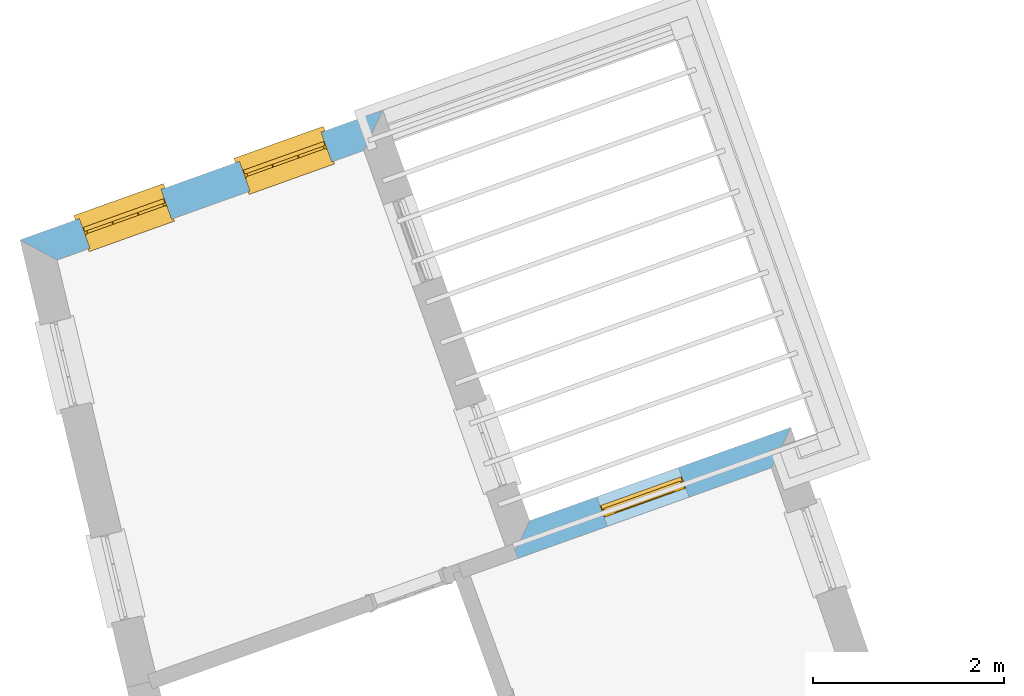
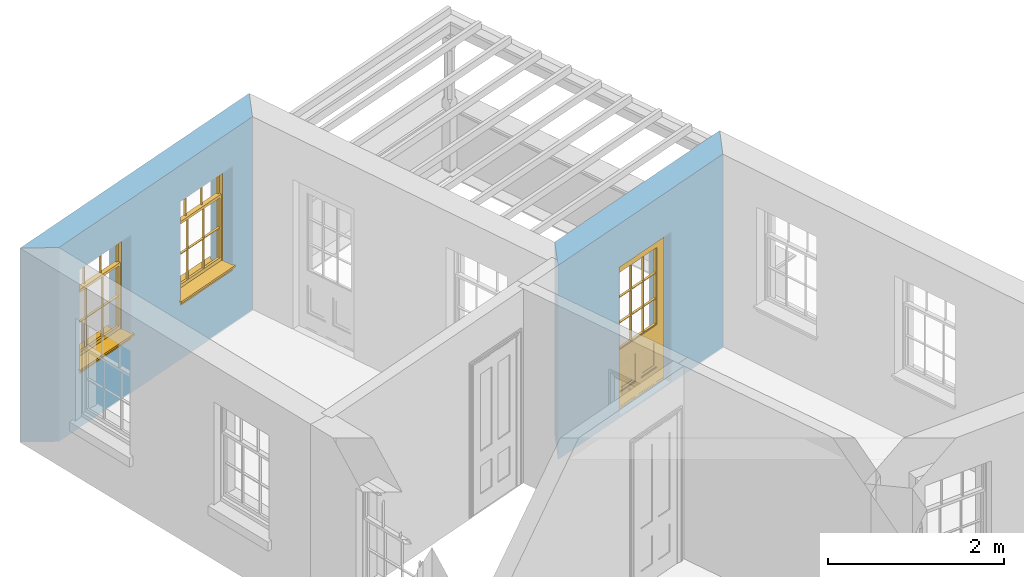
# One storey, part 10 of 12: 2 windows, 1 door, 3 openings, plus 2 elements that do not belong to this part.
"""IFC2X3 building model written with IfcOpenShell, lengths in metres."""

from ifc_helpers import new_model, si_unit, frame, origin, place, context, subcontext, project, spatial, polyline, outline, extrude, faceted_brep, material, layer, layer_set, layer_usage, element, fill, save


model = new_model("IFC2X3")

# Units and contexts
model_context = context("Model", 3, world=origin())
body_context = subcontext(model_context, "Body", "Model", "MODEL_VIEW")
ifc_project = project(units=[si_unit("PLANEANGLEUNIT", "RADIAN"), si_unit("MASSUNIT", "GRAM", prefix="KILO"), si_unit("FORCEUNIT", "NEWTON", prefix="KILO"), si_unit("LENGTHUNIT", "METRE")], contexts=[model_context])

# Site, building, storey
site_placement = place(None, origin())
site = spatial("IfcSite", under=ifc_project, at=site_placement, CompositionType="ELEMENT")
building_placement = place(None, origin())
building = spatial("IfcBuilding", under=site, at=building_placement, Name="Building plot-12", CompositionType="ELEMENT")
storey_placement = place(None, frame((0.0, 0.0, 6.45)))
storey = spatial("IfcBuildingStorey", under=building, at=storey_placement, Name="Floor 1", CompositionType="ELEMENT", Elevation=6.45)

# Wall, opening, door
ifc_material = material(Name="Masonry")
ifc_layer = layer(ifc_material, 0.33, ventilated=False)
ifc_layer_set = layer_set([ifc_layer], Name="My Wall")
ifc_layer_usage = layer_usage(ifc_layer_set, "AXIS2", "NEGATIVE", 0.08)
wall_1_placement = place(storey_placement, origin())
wall_1 = element("IfcWallStandardCase", 1, at=wall_1_placement, inside=storey, material=ifc_layer_usage, Name="exterior", context=body_context, shape_type="SweptSolid", body=[
    extrude(outline(polyline([(60.6224114250311, 40.801918386454), (60.8252944529976, 41.2249256313146), (58.0905645178046, 40.247064339734), (57.8909410000931, 39.8252226026139), (60.6224114250311, 40.801918386454)])), origin(), (0.0, 0.0, 1.0), 2.7),
])
opening_1_placement = place(storey_placement, frame((0.0, 0.0, 0.0199999999999996)))
opening_1 = element("IfcOpeningElement", 2, at=opening_1_placement, cuts=wall_1, Name="Opening", ObjectType="Opening", context=body_context, shape_type="SweptSolid", body=[
    extrude(outline(polyline([(59.6497256970325, 40.804575831045), (58.7928569365829, 40.4981840436785), (58.9039660462872, 40.1874514162628), (59.7608348067368, 40.4938432036292), (59.6497256970325, 40.804575831045)])), origin(), (0.0, 0.0, 1.0), 2.08),
])
door_placement = place(storey_placement, frame((59.7338992649903, 40.569172325427, 0.0199999999999996), z_axis=(0.0, 0.0, 1.0), x_axis=(-0.856868760449572, -0.306391787366451, 0.0)))
door = element("IfcDoor", 3, at=door_placement, inside=storey, Name="bedroom outside door", OverallHeight=2.08, OverallWidth=0.91, context=body_context, shape_type="Brep", held_by="IfcProductRepresentation", body=[
    faceted_brep([(0.545, -0.055, 0.265), (0.745, -0.055, 0.265), (0.745, -0.05, 0.265), (0.545, -0.05, 0.265), (0.745, -0.05, 0.58), (0.545, -0.05, 0.58), (0.545, -0.055, 0.58), (0.515, -0.06, 0.235), (0.775, -0.06, 0.235), (0.745, -0.055, 0.58), (0.515, -0.06, 0.61), (0.515, -0.065, 0.235), (0.775, -0.065, 0.235), (0.775, -0.06, 0.61), (0.515, -0.065, 0.61), (0.785, -0.065, 0.225), (0.505, -0.065, 0.225), (0.775, -0.065, 0.61), (0.505, -0.065, 0.62), (0.785, -0.065, 0.62), (0.505, -0.07, 0.225), (0.785, -0.07, 0.225), (0.505, -0.07, 0.62), (0.785, -0.07, 0.62), (0.883, -0.07, 0.075), (0.898, -0.07, 0.075), (0.405, -0.07, 0.62), (0.405, -0.07, 0.225), (0.027, -0.07, 0.075), (0.785, -0.07, 0.82), (0.125, -0.07, 0.82), (0.405, -0.065, 0.62), (0.405, -0.065, 0.225), (0.898, -0.07, 2.068), (0.027, -0.08, 0.075), (0.883, -0.08, 0.075), (0.125, -0.07, 0.225), (0.012, -0.07, 0.075), (0.785, -0.06, 0.82), (0.125, -0.06, 0.82), (0.125, -0.07, 0.62), (0.125, -0.065, 0.62), (0.395, -0.065, 0.61), (0.395, -0.065, 0.235), (0.125, -0.065, 0.225), (0.785, -0.07, 1.895), (0.027, -0.11, 0.045), (0.883, -0.11, 0.045), (0.558333, -0.06, 0.83), (0.351667, -0.06, 0.83), (0.125, -0.07, 1.895), (0.125, -0.06, 1.895), (0.785, -0.06, 1.895), (0.012, -0.07, 2.068), (0.135, -0.065, 0.61), (0.395, -0.06, 0.61), (0.395, -0.06, 0.235), (0.135, -0.065, 0.235), (0.027, -0.11, 0.027), (0.883, -0.11, 0.027), (0.568333, -0.06, 0.83), (0.558333, -0.03, 0.83), (0.351667, -0.03, 0.83), (0.341667, -0.06, 0.83), (0.135, -0.06, 1.185), (0.135, -0.06, 1.53), (0.775, -0.06, 1.53), (0.775, -0.06, 1.185), (0.135, -0.06, 0.61), (0.365, -0.055, 0.58), (0.365, -0.055, 0.265), (0.135, -0.06, 0.235), (0.568333, -0.06, 1.175), (0.558333, -0.06, 1.175), (0.775, -0.06, 0.83), (0.558333, -0.03, 1.175), (0.785, -0.03, 0.82), (0.125, -0.03, 0.82), (0.351667, -0.03, 1.175), (0.351667, -0.06, 1.175), (0.341667, -0.06, 1.175), (0.135, -0.06, 0.83), (0.135, -0.06, 1.175), (0.135, -0.03, 1.185), (0.135, -0.03, 1.53), (0.135, -0.06, 1.54), (0.351667, -0.06, 1.885), (0.558333, -0.06, 1.885), (0.775, -0.03, 1.53), (0.775, -0.03, 1.185), (0.775, -0.06, 1.175), (0.775, -0.06, 1.54), (0.165, -0.055, 0.58), (0.365, -0.05, 0.58), (0.365, -0.05, 0.265), (0.165, -0.055, 0.265), (0.568333, -0.03, 0.83), (0.568333, -0.03, 1.175), (0.568333, -0.06, 1.185), (0.558333, -0.06, 1.185), (0.775, -0.03, 0.83), (0.785, -0.02, 0.82), (0.125, -0.02, 0.82), (0.341667, -0.03, 0.83), (0.341667, -0.03, 1.175), (0.351667, -0.06, 1.185), (0.341667, -0.06, 1.185), (0.135, -0.03, 0.83), (0.341667, -0.03, 1.185), (0.125, -0.03, 1.895), (0.341667, -0.03, 1.53), (0.341667, -0.06, 1.53), (0.135, -0.06, 1.885), (0.341667, -0.06, 1.54), (0.341667, -0.06, 1.885), (0.558333, -0.03, 1.885), (0.351667, -0.03, 1.885), (0.568333, -0.06, 1.885), (0.785, -0.03, 1.895), (0.568333, -0.03, 1.185), (0.568333, -0.06, 1.53), (0.568333, -0.03, 1.53), (0.568333, -0.06, 1.54), (0.775, -0.06, 1.885), (0.165, -0.05, 0.58), (0.165, -0.05, 0.265), (0.775, -0.03, 1.175), (0.558333, -0.06, 1.53), (0.351667, -0.03, 1.185), (0.558333, -0.03, 1.185), (0.505, -0.02, 0.62), (0.405, -0.02, 0.62), (0.125, -0.02, 1.895), (0.785, -0.02, 1.895), (0.351667, -0.06, 1.53), (0.135, -0.03, 1.175), (0.135, -0.03, 1.54), (0.341667, -0.03, 1.54), (0.135, -0.03, 1.885), (0.351667, -0.06, 1.54), (0.558333, -0.03, 1.54), (0.558333, -0.06, 1.54), (0.351667, -0.03, 1.54), (0.775, -0.03, 1.54), (0.568333, -0.03, 1.54), (0.775, -0.03, 1.885), (0.558333, -0.03, 1.53), (0.405, -0.02, 0.225), (0.505, -0.02, 0.225), (0.125, -0.02, 0.62), (0.785, -0.02, 0.62), (0.012, -0.02, 2.068), (0.898, -0.02, 2.068), (0.351667, -0.03, 1.53), (0.341667, -0.03, 1.885), (0.568333, -0.03, 1.885), (0.405, -0.025, 0.225), (0.405, -0.025, 0.62), (0.505, -0.025, 0.62), (0.505, -0.025, 0.225), (0.898, -0.02, 0.027), (0.012, -0.02, 0.027), (0.125, -0.025, 0.62), (0.785, -0.025, 0.62), (0.395, -0.025, 0.235), (0.395, -0.025, 0.61), (0.125, -0.02, 0.225), (0.125, -0.025, 0.225), (0.515, -0.025, 0.61), (0.515, -0.025, 0.235), (0.785, -0.02, 0.225), (0.785, -0.025, 0.225), (0.135, -0.025, 0.61), (0.775, -0.025, 0.61), (0.135, -0.025, 0.235), (0.395, -0.03, 0.235), (0.395, -0.03, 0.61), (0.515, -0.03, 0.61), (0.515, -0.03, 0.235), (0.775, -0.025, 0.235), (0.135, -0.03, 0.61), (0.775, -0.03, 0.61), (0.135, -0.03, 0.235), (0.365, -0.035, 0.265), (0.365, -0.035, 0.58), (0.545, -0.035, 0.58), (0.545, -0.035, 0.265), (0.775, -0.03, 0.235), (0.165, -0.035, 0.58), (0.745, -0.035, 0.58), (0.165, -0.035, 0.265), (0.365, -0.04, 0.58), (0.365, -0.04, 0.265), (0.545, -0.04, 0.58), (0.545, -0.04, 0.265), (0.745, -0.035, 0.265), (0.165, -0.04, 0.58), (0.745, -0.04, 0.58), (0.165, -0.04, 0.265), (0.745, -0.04, 0.265), (0.885, -0.072, 0.025), (0.025, -0.072, 0.025), (0.025, -0.1, 0.025), (0.885, -0.1, 0.025), (0.9, -0.02, 0.025), (0.01, -0.02, 0.025), (0.9, -0.072, 0.025), (0.91, -0.02, 0.0), (0.0, -0.02, 0.0), (0.01, -0.072, 0.025), (0.9, -0.072, 2.07), (0.9, -0.02, 2.07), (0.885, -0.072, 2.055), (0.91, -0.02, 2.08), (0.01, -0.02, 2.07), (0.0, -0.02, 2.08), (0.01, -0.072, 2.07), (0.025, -0.072, 2.055), (0.0, -0.15, 2.08), (0.91, -0.15, 2.08), (0.01, -0.15, 2.07), (0.9, -0.15, 2.07), (0.01, -0.1, 2.07), (0.9, -0.1, 2.07), (0.0, -0.15, 0.0), (0.91, -0.15, 0.0), (0.01, -0.15, 0.025), (0.9, -0.15, 0.025), (0.01, -0.1, 0.025), (0.025, -0.1, 2.055), (0.9, -0.1, 0.025), (0.885, -0.1, 2.055), (0.898, -0.07, 0.027), (0.012, -0.07, 0.027), (0.883, -0.07, 0.027), (0.027, -0.07, 0.027)], [[[0, 1, 2, 3]], [[2, 4, 5, 3]], [[0, 3, 5, 6]], [[1, 0, 7, 8]], [[9, 4, 2, 1]], [[9, 6, 5, 4]], [[0, 6, 10, 7]], [[8, 7, 11, 12]], [[8, 13, 9, 1]], [[13, 10, 6, 9]], [[7, 10, 14, 11]], [[15, 12, 11, 16]], [[12, 17, 13, 8]], [[17, 14, 10, 13]], [[18, 16, 11, 14]], [[15, 19, 17, 12]], [[15, 16, 20, 21]], [[14, 17, 19, 18]], [[16, 18, 22, 20]], [[21, 23, 19, 15]], [[24, 25, 21, 20]], [[23, 22, 18, 19]], [[20, 22, 26, 27]], [[23, 21, 25]], [[28, 24, 20, 27]], [[22, 23, 29]], [[29, 30, 26, 22]], [[27, 26, 31, 32]], [[23, 25, 33, 29]], [[34, 35, 24, 28]], [[28, 27, 36, 37]], [[38, 39, 30, 29]], [[26, 30, 40]], [[26, 40, 41, 31]], [[42, 43, 32, 31]], [[32, 44, 36, 27]], [[33, 45, 29]], [[46, 47, 35, 34]], [[36, 40, 37]], [[39, 38, 48, 49]], [[50, 30, 39, 51]], [[29, 45, 52, 38]], [[53, 37, 40, 30]], [[44, 41, 40, 36]], [[31, 41, 54, 42]], [[43, 42, 55, 56]], [[57, 44, 32, 43]], [[50, 45, 33, 53]], [[47, 46, 58, 59]], [[60, 48, 38]], [[49, 48, 61, 62]], [[49, 63, 39]], [[50, 53, 30]], [[51, 39, 64, 65]], [[45, 50, 51, 52]], [[66, 67, 38, 52]], [[57, 54, 41, 44]], [[42, 54, 68, 55]], [[56, 55, 69, 70]], [[56, 71, 57, 43]], [[60, 72, 73, 48]], [[60, 38, 74]], [[48, 73, 75, 61]], [[76, 77, 62, 61]], [[62, 78, 79, 49]], [[49, 79, 80, 63]], [[63, 81, 39]], [[82, 64, 39]], [[65, 64, 83, 84]], [[85, 51, 65]], [[52, 51, 86, 87]], [[88, 89, 67, 66]], [[90, 38, 67]], [[91, 66, 52]], [[71, 68, 54, 57]], [[55, 68, 92, 69]], [[69, 93, 94, 70]], [[70, 95, 71, 56]], [[96, 97, 72, 60]], [[73, 72, 98, 99]], [[74, 38, 90]], [[100, 96, 60, 74]], [[75, 73, 79, 78]], [[61, 75, 97, 96]], [[101, 102, 77, 76]], [[77, 103, 62]], [[96, 76, 61]], [[103, 104, 78, 62]], [[80, 79, 105, 106]], [[63, 80, 104, 103]], [[81, 63, 103, 107]], [[81, 82, 39]], [[106, 64, 82, 80]], [[106, 108, 83, 64]], [[84, 83, 77, 109]], [[110, 111, 65, 84]], [[112, 51, 85]], [[113, 85, 65, 111]], [[114, 86, 51]], [[115, 87, 86, 116]], [[117, 52, 87]], [[118, 76, 89, 88]], [[119, 98, 67, 89]], [[120, 121, 88, 66]], [[67, 98, 72, 90]], [[91, 122, 120, 66]], [[91, 52, 123]], [[95, 92, 68, 71]], [[69, 92, 124, 93]], [[94, 93, 124, 125]], [[94, 125, 95, 70]], [[72, 97, 126, 90]], [[127, 99, 98, 120]], [[99, 105, 79, 73]], [[74, 90, 126, 100]], [[96, 100, 76]], [[128, 129, 75, 78]], [[97, 75, 129, 119]], [[130, 131, 102, 101]], [[109, 77, 102, 132]], [[133, 101, 76, 118]], [[77, 107, 103]], [[78, 104, 108, 128]], [[111, 106, 105, 134]], [[104, 80, 82, 135]], [[107, 135, 82, 81]], [[110, 108, 106, 111]], [[104, 135, 83, 108]], [[83, 135, 77]], [[136, 84, 109]], [[110, 84, 136, 137]], [[114, 51, 112]], [[85, 136, 138, 112]], [[113, 137, 136, 85]], [[111, 134, 139, 113]], [[86, 114, 113, 139]], [[140, 141, 87, 115]], [[139, 142, 116, 86]], [[109, 118, 115, 116]], [[117, 123, 52]], [[117, 87, 141, 122]], [[126, 89, 76]], [[143, 118, 88]], [[120, 98, 119, 121]], [[119, 89, 126, 97]], [[144, 143, 88, 121]], [[144, 122, 91, 143]], [[127, 120, 122, 141]], [[143, 91, 123, 145]], [[124, 92, 95, 125]], [[146, 129, 99, 127]], [[99, 129, 128, 105]], [[100, 126, 76]], [[121, 119, 129, 146]], [[147, 131, 130, 148]], [[131, 149, 102]], [[130, 101, 150]], [[102, 151, 132]], [[118, 109, 132, 133]], [[101, 133, 152]], [[107, 77, 135]], [[153, 128, 108, 110]], [[134, 105, 128, 153]], [[109, 138, 136]], [[153, 110, 137, 142]], [[154, 114, 112, 138]], [[137, 113, 114, 154]], [[141, 139, 134, 127]], [[141, 140, 142, 139]], [[144, 140, 115, 155]], [[142, 137, 154, 116]], [[155, 115, 118]], [[116, 154, 109]], [[117, 155, 145, 123]], [[122, 144, 155, 117]], [[143, 145, 118]], [[121, 146, 140, 144]], [[146, 127, 134, 153]], [[156, 157, 131, 147]], [[148, 130, 158, 159]], [[148, 160, 161, 147]], [[157, 162, 149, 131]], [[161, 151, 102, 149]], [[101, 152, 160, 150]], [[163, 158, 130, 150]], [[151, 152, 133, 132]], [[154, 138, 109]], [[142, 140, 146, 153]], [[145, 155, 118]], [[157, 156, 164, 165]], [[147, 166, 167, 156]], [[168, 169, 159, 158]], [[170, 148, 159, 171]], [[148, 170, 160]], [[166, 147, 161]], [[172, 162, 157, 165]], [[166, 149, 162, 167]], [[166, 161, 149]], [[150, 160, 170]], [[163, 173, 168, 158]], [[171, 163, 150, 170]], [[174, 164, 156, 167]], [[175, 176, 165, 164]], [[169, 168, 177, 178]], [[171, 159, 169, 179]], [[167, 162, 172, 174]], [[176, 180, 172, 165]], [[179, 173, 163, 171]], [[181, 177, 168, 173]], [[164, 174, 182, 175]], [[183, 184, 176, 175]], [[178, 177, 185, 186]], [[179, 169, 178, 187]], [[174, 172, 180, 182]], [[184, 188, 180, 176]], [[187, 181, 173, 179]], [[189, 185, 177, 181]], [[175, 182, 190, 183]], [[191, 184, 183, 192]], [[185, 193, 194, 186]], [[187, 178, 186, 195]], [[182, 180, 188, 190]], [[191, 196, 188, 184]], [[195, 189, 181, 187]], [[197, 193, 185, 189]], [[183, 190, 198, 192]], [[198, 196, 191, 192]], [[194, 193, 197, 199]], [[195, 186, 194, 199]], [[188, 196, 198, 190]], [[197, 189, 195, 199]], [[200, 201, 202, 203]], [[201, 200, 204, 205]], [[206, 204, 200]], [[204, 207, 208, 205]], [[209, 201, 205]], [[210, 211, 204, 206]], [[206, 200, 212, 210]], [[211, 213, 207, 204]], [[214, 205, 208, 215]], [[216, 217, 201, 209]], [[205, 214, 216, 209]], [[216, 214, 211, 210]], [[210, 212, 217, 216]], [[214, 215, 213, 211]], [[218, 219, 213, 215]], [[219, 218, 220, 221]], [[221, 220, 222, 223]], [[215, 208, 224, 218]], [[225, 224, 208, 207]], [[224, 226, 220, 218]], [[224, 225, 227, 226]], [[219, 225, 207, 213]], [[228, 222, 220, 226]], [[219, 221, 227, 225]], [[226, 227, 203, 202]], [[202, 229, 222, 228]], [[228, 226, 202]], [[227, 221, 223, 230]], [[230, 203, 227]], [[217, 229, 202, 201]], [[231, 223, 222, 229]], [[230, 223, 231, 203]], [[231, 229, 217, 212]], [[212, 200, 203, 231]], [[33, 152, 151, 53]], [[25, 160, 152, 33]], [[161, 37, 53, 151]], [[232, 160, 25]], [[161, 233, 37]], [[160, 232, 234]], [[24, 234, 232, 25]], [[233, 161, 235]], [[37, 233, 235, 28]], [[161, 160, 234, 235]], [[35, 47, 234, 24]], [[28, 235, 46, 34]], [[58, 235, 234, 59]], [[59, 234, 47]], [[58, 46, 235]]]),
])
fill(opening_1, door)

# Wall, openings, windows
wall_2_placement = place(storey_placement, origin())
wall_2 = element("IfcWallStandardCase", 4, at=wall_2_placement, inside=storey, material=ifc_layer_usage, Name="exterior", context=body_context, shape_type="SweptSolid", body=[
    extrude(outline(polyline([(56.3536968527592, 44.1243472572147), (56.5533203704707, 44.5461889943348), (52.7542538663581, 43.1877513545865), (53.1438565991735, 42.9766000900277), (56.3536968527592, 44.1243472572147)])), origin(), (0.0, 0.0, 1.0), 2.7),
])
opening_2_placement = place(storey_placement, frame((0.0, 0.0, 0.75)))
opening_2 = element("IfcOpeningElement", 5, at=opening_2_placement, cuts=wall_2, Name="Opening", ObjectType="Opening", context=body_context, shape_type="SweptSolid", body=[
    extrude(outline(polyline([(55.9081804998309, 44.3155054087142), (55.0513117393813, 44.0091136213478), (55.1624208490857, 43.698380993932), (56.0192896095352, 44.0047727812985), (55.9081804998309, 44.3155054087142)])), origin(), (0.0, 0.0, 1.0), 1.445),
])
opening_3_placement = place(storey_placement, frame((0.0, 0.0, 0.75)))
opening_3 = element("IfcOpeningElement", 6, at=opening_3_placement, cuts=wall_2, Name="Opening", ObjectType="Opening", context=body_context, shape_type="SweptSolid", body=[
    extrude(outline(polyline([(54.2318390093378, 43.7160935860224), (53.3749702488882, 43.409701798656), (53.4860793585926, 43.0989691712402), (54.3429481190421, 43.4053609586067), (54.2318390093378, 43.7160935860224)])), origin(), (0.0, 0.0, 1.0), 1.445),
])
window_1_placement = place(storey_placement, frame((55.9923540677887, 44.0801019030962, 0.75), z_axis=(0.0, 0.0, 1.0), x_axis=(-0.856868760449572, -0.306391787366458, 0.0)))
window_1 = element("IfcWindow", 7, at=window_1_placement, inside=storey, Name="bedroom outside window", OverallHeight=1.445, OverallWidth=0.91, context=body_context, shape_type="Brep", held_by="IfcProductRepresentation", body=[
    faceted_brep([(0.876875, -0.105, 0.999097), (0.876875, -0.105, 1.411875), (0.9, -0.105, 1.435), (0.033125, -0.105, 1.411875), (0.033125, -0.105, 0.999097), (0.01, -0.105, 1.435), (0.033125, -0.135, 1.411875), (0.01, -0.135, 1.435), (0.033125, -0.135, 0.999097), (0.876875, -0.135, 1.411875), (0.876875, -0.135, 0.999097), (0.9, -0.135, 1.435), (0.033125, -0.105, 0.960972), (0.01, -0.105, 0.960972), (0.033125, -0.105, 0.548195), (0.876875, -0.105, 0.960972), (0.876875, -0.105, 0.548195), (0.9, -0.105, 0.960972), (0.876875, -0.105, 0.538195), (0.876875, -0.105, 0.125417), (0.9, -0.105, 0.077167), (0.033125, -0.105, 0.125417), (0.033125, -0.105, 0.538195), (0.01, -0.105, 0.077167), (0.9, -0.135, 0.960972), (0.01, -0.135, 0.960972), (-0.0425, -0.25, 0.01), (-0.0425, -0.3, 0.001667), (0.0, -0.25, 0.01), (0.9525, -0.25, 0.01), (0.91, -0.25, 0.01), (0.9525, -0.3, 0.001667), (-0.02, 0.08, 0.077167), (0.0, 0.08, 0.077167), (-0.02, 0.11, 0.077167), (0.0, -0.06, 0.077167), (0.01, -0.06, 0.077167), (0.91, -0.06, 0.077167), (0.91, 0.08, 0.077167), (0.9, -0.06, 0.077167), (0.93, 0.08, 0.077167), (0.93, 0.11, 0.077167), (0.01, -0.105, 0.999097), (0.01, -0.075, 0.999097), (0.9, -0.105, 0.999097), (0.9, -0.075, 0.999097), (0.876875, -0.075, 0.125417), (0.876875, -0.075, 0.538195), (0.9, -0.075, 0.077167), (0.876875, -0.075, 0.548195), (0.876875, -0.075, 0.960972), (0.033125, -0.075, 0.125417), (0.01, -0.075, 0.077167), (0.033125, -0.075, 0.538195), (0.033125, -0.075, 0.960972), (0.033125, -0.075, 0.548195), (-0.02, 0.08, 0.052167), (-0.02, 0.11, 0.052167), (0.93, 0.11, 0.052167), (0.93, 0.08, 0.052167), (0.91, 0.08, 0.052167), (0.0, 0.08, 0.052167), (0.91, -0.15, 0.026667), (0.0, -0.15, 0.026667), (-0.0425, -0.3, -0.123333), (0.9525, -0.3, -0.123333), (-0.0425, -0.25, -0.123333), (0.9525, -0.25, -0.123333), (0.01, -0.06, 1.435), (0.9, -0.06, 1.435), (0.0, -0.06, 1.445), (0.91, -0.06, 1.445), (0.01, -0.15, 0.077167), (0.9, -0.15, 0.077167), (0.592292, -0.105, 0.125417), (0.592292, -0.075, 0.125417), (0.317708, -0.075, 0.125417), (0.317708, -0.105, 0.125417), (0.592292, -0.105, 0.548195), (0.317708, -0.105, 0.548195), (0.317708, -0.105, 0.538195), (0.592292, -0.105, 0.538195), (0.592292, -0.075, 0.548195), (0.317708, -0.075, 0.548195), (0.602292, -0.075, 0.548195), (0.602292, -0.105, 0.548195), (0.317708, -0.075, 0.538195), (0.307708, -0.075, 0.125417), (0.307708, -0.075, 0.538195), (0.602292, -0.075, 0.538195), (0.602292, -0.075, 0.125417), (0.592292, -0.075, 0.538195), (0.307708, -0.075, 0.548195), (0.317708, -0.075, 0.960972), (0.307708, -0.075, 0.960972), (0.602292, -0.075, 0.960972), (0.592292, -0.075, 0.960972), (0.307708, -0.105, 0.538195), (0.307708, -0.105, 0.125417), (0.307708, -0.105, 0.548195), (0.307708, -0.105, 0.960972), (0.592292, -0.105, 0.960972), (0.317708, -0.105, 0.960972), (0.602292, -0.105, 0.960972), (0.602292, -0.105, 0.538195), (0.602292, -0.105, 0.125417), (0.317708, -0.135, 1.411875), (0.307708, -0.135, 1.411875), (0.307708, -0.135, 0.999097), (0.317708, -0.135, 0.999097), (0.602292, -0.135, 1.411875), (0.592292, -0.135, 1.411875), (0.592292, -0.135, 0.999097), (0.602292, -0.135, 0.999097), (0.317708, -0.105, 0.999097), (0.307708, -0.105, 0.999097), (0.307708, -0.105, 1.411875), (0.317708, -0.105, 1.411875), (0.602292, -0.105, 0.999097), (0.592292, -0.105, 0.999097), (0.592292, -0.105, 1.411875), (0.602292, -0.105, 1.411875), (0.91, -0.15, 1.445), (0.9, -0.15, 1.435), (0.01, -0.15, 1.435), (0.0, -0.15, 1.445), (0.91, -0.25, 0.0), (0.0, -0.25, 0.0), (0.91, 0.08, 0.0), (0.0, 0.08, 0.0)], [[[0, 1, 2]], [[3, 4, 5]], [[6, 7, 8]], [[9, 10, 11]], [[12, 13, 14]], [[15, 16, 17]], [[18, 19, 20]], [[21, 22, 23]], [[24, 15, 17]], [[13, 12, 25]], [[26, 27, 28]], [[29, 30, 31]], [[32, 33, 34]], [[35, 36, 33]], [[37, 38, 39]], [[40, 41, 38]], [[42, 4, 43]], [[44, 45, 0]], [[46, 47, 48]], [[49, 50, 45]], [[51, 52, 53]], [[54, 55, 43]], [[38, 33, 36, 39]], [[41, 34, 33, 38]], [[56, 32, 34, 57]], [[57, 34, 41, 58]], [[58, 41, 40, 59]], [[57, 58, 60, 61]], [[52, 48, 39, 36]], [[62, 63, 28, 30]], [[27, 31, 30, 28]], [[27, 64, 65, 31]], [[66, 67, 65, 64]], [[2, 5, 68, 69]], [[68, 70, 71, 69]], [[20, 23, 72, 73]], [[73, 72, 63, 62]], [[74, 75, 76, 77]], [[78, 79, 80, 81]], [[78, 82, 83, 79]], [[16, 49, 84, 85]], [[86, 76, 87, 88]], [[89, 90, 75, 91]], [[92, 88, 53, 55]], [[82, 91, 86, 83]], [[93, 83, 92, 94]], [[95, 84, 82, 96]], [[89, 84, 49, 47]], [[97, 88, 87, 98]], [[22, 53, 88, 97]], [[81, 91, 75, 74]], [[80, 86, 91, 81]], [[77, 76, 86, 80]], [[99, 92, 55, 14]], [[100, 94, 92, 99]], [[101, 96, 82, 78]], [[79, 83, 93, 102]], [[85, 84, 95, 103]], [[104, 89, 47, 18]], [[105, 90, 89, 104]], [[104, 18, 16, 85]], [[80, 97, 98, 77]], [[104, 81, 74, 105]], [[103, 101, 78, 85]], [[99, 14, 22, 97]], [[102, 100, 99, 79]], [[106, 107, 108, 109]], [[110, 111, 112, 113]], [[114, 115, 116, 117]], [[118, 119, 120, 121]], [[107, 116, 115, 108]], [[111, 120, 119, 112]], [[109, 114, 117, 106]], [[113, 118, 121, 110]], [[85, 78, 81, 104]], [[84, 89, 91, 82]], [[83, 86, 88, 92]], [[79, 99, 97, 80]], [[109, 112, 119, 114]], [[102, 93, 96, 101]], [[106, 117, 120, 111]], [[98, 87, 51, 21]], [[6, 3, 116, 107]], [[110, 121, 1, 9]], [[19, 46, 90, 105]], [[26, 66, 64, 27]], [[29, 31, 65, 67]], [[25, 24, 112, 109]], [[11, 7, 106, 111]], [[75, 48, 52, 76]], [[43, 45, 96, 93]], [[45, 43, 114, 119]], [[5, 2, 120, 117]], [[24, 25, 102, 101]], [[42, 5, 4]], [[2, 44, 0]], [[49, 45, 48, 47]], [[52, 43, 55, 53]], [[14, 13, 23, 22]], [[20, 17, 16, 18]], [[24, 11, 10]], [[25, 8, 7]], [[8, 4, 3, 6]], [[9, 1, 0, 10]], [[15, 50, 49, 16]], [[18, 47, 46, 19]], [[21, 51, 53, 22]], [[14, 55, 54, 12]], [[44, 2, 69, 45]], [[68, 5, 42, 43]], [[36, 35, 70, 68]], [[39, 69, 71, 37]], [[62, 122, 123, 73]], [[63, 72, 124, 125]], [[8, 108, 115, 4]], [[113, 10, 0, 118]], [[94, 100, 12, 54]], [[17, 20, 73, 24]], [[72, 23, 13, 25]], [[52, 36, 68, 43]], [[69, 39, 48, 45]], [[11, 24, 73, 123]], [[7, 124, 72, 25]], [[23, 77, 98]], [[98, 21, 23]], [[105, 74, 20]], [[20, 19, 105]], [[20, 74, 77, 23]], [[113, 112, 24]], [[24, 10, 113]], [[25, 109, 108]], [[108, 8, 25]], [[110, 9, 11]], [[11, 111, 110]], [[7, 6, 107]], [[107, 106, 7]], [[5, 117, 116]], [[116, 3, 5]], [[121, 120, 2]], [[2, 1, 121]], [[11, 123, 124, 7]], [[122, 125, 124, 123]], [[43, 93, 94]], [[94, 54, 43]], [[96, 45, 95]], [[50, 95, 45]], [[15, 103, 95, 50]], [[48, 75, 90]], [[90, 46, 48]], [[87, 76, 52]], [[52, 51, 87]], [[103, 15, 24]], [[24, 101, 103]], [[100, 102, 25]], [[25, 12, 100]], [[115, 114, 43]], [[43, 4, 115]], [[118, 0, 45]], [[45, 119, 118]], [[71, 70, 125, 122]], [[70, 35, 63, 125]], [[122, 62, 37, 71]], [[126, 67, 66, 127]], [[60, 58, 59]], [[38, 60, 59, 40]], [[61, 56, 57]], [[32, 56, 61, 33]], [[61, 60, 128, 129]], [[62, 60, 38, 37]], [[126, 128, 60, 62]], [[33, 61, 63, 35]], [[61, 129, 127, 63]], [[128, 126, 127, 129]], [[28, 127, 66, 26]], [[63, 127, 28]], [[29, 67, 126, 30]], [[30, 126, 62]]]),
])
fill(opening_2, window_1)
window_2_placement = place(storey_placement, frame((54.3160125772956, 43.4806900804044, 0.75), z_axis=(0.0, 0.0, 1.0), x_axis=(-0.856868760449572, -0.306391787366458, 0.0)))
window_2 = element("IfcWindow", 8, at=window_2_placement, inside=storey, Name="bedroom outside window", OverallHeight=1.445, OverallWidth=0.91, context=body_context, shape_type="Brep", held_by="IfcProductRepresentation", body=[
    faceted_brep([(0.876875, -0.105, 0.999097), (0.876875, -0.105, 1.411875), (0.9, -0.105, 1.435), (0.033125, -0.105, 1.411875), (0.033125, -0.105, 0.999097), (0.01, -0.105, 1.435), (0.033125, -0.135, 1.411875), (0.01, -0.135, 1.435), (0.033125, -0.135, 0.999097), (0.876875, -0.135, 1.411875), (0.876875, -0.135, 0.999097), (0.9, -0.135, 1.435), (0.033125, -0.105, 0.960972), (0.01, -0.105, 0.960972), (0.033125, -0.105, 0.548195), (0.876875, -0.105, 0.960972), (0.876875, -0.105, 0.548195), (0.9, -0.105, 0.960972), (0.876875, -0.105, 0.538195), (0.876875, -0.105, 0.125417), (0.9, -0.105, 0.077167), (0.033125, -0.105, 0.125417), (0.033125, -0.105, 0.538195), (0.01, -0.105, 0.077167), (0.9, -0.135, 0.960972), (0.01, -0.135, 0.960972), (-0.0425, -0.25, 0.01), (-0.0425, -0.3, 0.001667), (0.0, -0.25, 0.01), (0.9525, -0.25, 0.01), (0.91, -0.25, 0.01), (0.9525, -0.3, 0.001667), (-0.02, 0.08, 0.077167), (0.0, 0.08, 0.077167), (-0.02, 0.11, 0.077167), (0.0, -0.06, 0.077167), (0.01, -0.06, 0.077167), (0.91, -0.06, 0.077167), (0.91, 0.08, 0.077167), (0.9, -0.06, 0.077167), (0.93, 0.08, 0.077167), (0.93, 0.11, 0.077167), (0.01, -0.105, 0.999097), (0.01, -0.075, 0.999097), (0.9, -0.105, 0.999097), (0.9, -0.075, 0.999097), (0.876875, -0.075, 0.125417), (0.876875, -0.075, 0.538195), (0.9, -0.075, 0.077167), (0.876875, -0.075, 0.548195), (0.876875, -0.075, 0.960972), (0.033125, -0.075, 0.125417), (0.01, -0.075, 0.077167), (0.033125, -0.075, 0.538195), (0.033125, -0.075, 0.960972), (0.033125, -0.075, 0.548195), (-0.02, 0.08, 0.052167), (-0.02, 0.11, 0.052167), (0.93, 0.11, 0.052167), (0.93, 0.08, 0.052167), (0.91, 0.08, 0.052167), (0.0, 0.08, 0.052167), (0.91, -0.15, 0.026667), (0.0, -0.15, 0.026667), (-0.0425, -0.3, -0.123333), (0.9525, -0.3, -0.123333), (-0.0425, -0.25, -0.123333), (0.9525, -0.25, -0.123333), (0.01, -0.06, 1.435), (0.9, -0.06, 1.435), (0.0, -0.06, 1.445), (0.91, -0.06, 1.445), (0.01, -0.15, 0.077167), (0.9, -0.15, 0.077167), (0.592292, -0.105, 0.125417), (0.592292, -0.075, 0.125417), (0.317708, -0.075, 0.125417), (0.317708, -0.105, 0.125417), (0.592292, -0.105, 0.548195), (0.317708, -0.105, 0.548195), (0.317708, -0.105, 0.538195), (0.592292, -0.105, 0.538195), (0.592292, -0.075, 0.548195), (0.317708, -0.075, 0.548195), (0.602292, -0.075, 0.548195), (0.602292, -0.105, 0.548195), (0.317708, -0.075, 0.538195), (0.307708, -0.075, 0.125417), (0.307708, -0.075, 0.538195), (0.602292, -0.075, 0.538195), (0.602292, -0.075, 0.125417), (0.592292, -0.075, 0.538195), (0.307708, -0.075, 0.548195), (0.317708, -0.075, 0.960972), (0.307708, -0.075, 0.960972), (0.602292, -0.075, 0.960972), (0.592292, -0.075, 0.960972), (0.307708, -0.105, 0.538195), (0.307708, -0.105, 0.125417), (0.307708, -0.105, 0.548195), (0.307708, -0.105, 0.960972), (0.592292, -0.105, 0.960972), (0.317708, -0.105, 0.960972), (0.602292, -0.105, 0.960972), (0.602292, -0.105, 0.538195), (0.602292, -0.105, 0.125417), (0.317708, -0.135, 1.411875), (0.307708, -0.135, 1.411875), (0.307708, -0.135, 0.999097), (0.317708, -0.135, 0.999097), (0.602292, -0.135, 1.411875), (0.592292, -0.135, 1.411875), (0.592292, -0.135, 0.999097), (0.602292, -0.135, 0.999097), (0.317708, -0.105, 0.999097), (0.307708, -0.105, 0.999097), (0.307708, -0.105, 1.411875), (0.317708, -0.105, 1.411875), (0.602292, -0.105, 0.999097), (0.592292, -0.105, 0.999097), (0.592292, -0.105, 1.411875), (0.602292, -0.105, 1.411875), (0.91, -0.15, 1.445), (0.9, -0.15, 1.435), (0.01, -0.15, 1.435), (0.0, -0.15, 1.445), (0.91, -0.25, 0.0), (0.0, -0.25, 0.0), (0.91, 0.08, 0.0), (0.0, 0.08, 0.0)], [[[0, 1, 2]], [[3, 4, 5]], [[6, 7, 8]], [[9, 10, 11]], [[12, 13, 14]], [[15, 16, 17]], [[18, 19, 20]], [[21, 22, 23]], [[24, 15, 17]], [[13, 12, 25]], [[26, 27, 28]], [[29, 30, 31]], [[32, 33, 34]], [[35, 36, 33]], [[37, 38, 39]], [[40, 41, 38]], [[42, 4, 43]], [[44, 45, 0]], [[46, 47, 48]], [[49, 50, 45]], [[51, 52, 53]], [[54, 55, 43]], [[38, 33, 36, 39]], [[41, 34, 33, 38]], [[56, 32, 34, 57]], [[57, 34, 41, 58]], [[58, 41, 40, 59]], [[57, 58, 60, 61]], [[52, 48, 39, 36]], [[62, 63, 28, 30]], [[27, 31, 30, 28]], [[27, 64, 65, 31]], [[66, 67, 65, 64]], [[2, 5, 68, 69]], [[68, 70, 71, 69]], [[20, 23, 72, 73]], [[73, 72, 63, 62]], [[74, 75, 76, 77]], [[78, 79, 80, 81]], [[78, 82, 83, 79]], [[16, 49, 84, 85]], [[86, 76, 87, 88]], [[89, 90, 75, 91]], [[92, 88, 53, 55]], [[82, 91, 86, 83]], [[93, 83, 92, 94]], [[95, 84, 82, 96]], [[89, 84, 49, 47]], [[97, 88, 87, 98]], [[22, 53, 88, 97]], [[81, 91, 75, 74]], [[80, 86, 91, 81]], [[77, 76, 86, 80]], [[99, 92, 55, 14]], [[100, 94, 92, 99]], [[101, 96, 82, 78]], [[79, 83, 93, 102]], [[85, 84, 95, 103]], [[104, 89, 47, 18]], [[105, 90, 89, 104]], [[104, 18, 16, 85]], [[80, 97, 98, 77]], [[104, 81, 74, 105]], [[103, 101, 78, 85]], [[99, 14, 22, 97]], [[102, 100, 99, 79]], [[106, 107, 108, 109]], [[110, 111, 112, 113]], [[114, 115, 116, 117]], [[118, 119, 120, 121]], [[107, 116, 115, 108]], [[111, 120, 119, 112]], [[109, 114, 117, 106]], [[113, 118, 121, 110]], [[85, 78, 81, 104]], [[84, 89, 91, 82]], [[83, 86, 88, 92]], [[79, 99, 97, 80]], [[109, 112, 119, 114]], [[102, 93, 96, 101]], [[106, 117, 120, 111]], [[98, 87, 51, 21]], [[6, 3, 116, 107]], [[110, 121, 1, 9]], [[19, 46, 90, 105]], [[26, 66, 64, 27]], [[29, 31, 65, 67]], [[25, 24, 112, 109]], [[11, 7, 106, 111]], [[75, 48, 52, 76]], [[43, 45, 96, 93]], [[45, 43, 114, 119]], [[5, 2, 120, 117]], [[24, 25, 102, 101]], [[42, 5, 4]], [[2, 44, 0]], [[49, 45, 48, 47]], [[52, 43, 55, 53]], [[14, 13, 23, 22]], [[20, 17, 16, 18]], [[24, 11, 10]], [[25, 8, 7]], [[8, 4, 3, 6]], [[9, 1, 0, 10]], [[15, 50, 49, 16]], [[18, 47, 46, 19]], [[21, 51, 53, 22]], [[14, 55, 54, 12]], [[44, 2, 69, 45]], [[68, 5, 42, 43]], [[36, 35, 70, 68]], [[39, 69, 71, 37]], [[62, 122, 123, 73]], [[63, 72, 124, 125]], [[8, 108, 115, 4]], [[113, 10, 0, 118]], [[94, 100, 12, 54]], [[17, 20, 73, 24]], [[72, 23, 13, 25]], [[52, 36, 68, 43]], [[69, 39, 48, 45]], [[11, 24, 73, 123]], [[7, 124, 72, 25]], [[23, 77, 98]], [[98, 21, 23]], [[105, 74, 20]], [[20, 19, 105]], [[20, 74, 77, 23]], [[113, 112, 24]], [[24, 10, 113]], [[25, 109, 108]], [[108, 8, 25]], [[110, 9, 11]], [[11, 111, 110]], [[7, 6, 107]], [[107, 106, 7]], [[5, 117, 116]], [[116, 3, 5]], [[121, 120, 2]], [[2, 1, 121]], [[11, 123, 124, 7]], [[122, 125, 124, 123]], [[43, 93, 94]], [[94, 54, 43]], [[96, 45, 95]], [[50, 95, 45]], [[15, 103, 95, 50]], [[48, 75, 90]], [[90, 46, 48]], [[87, 76, 52]], [[52, 51, 87]], [[103, 15, 24]], [[24, 101, 103]], [[100, 102, 25]], [[25, 12, 100]], [[115, 114, 43]], [[43, 4, 115]], [[118, 0, 45]], [[45, 119, 118]], [[71, 70, 125, 122]], [[70, 35, 63, 125]], [[122, 62, 37, 71]], [[126, 67, 66, 127]], [[60, 58, 59]], [[38, 60, 59, 40]], [[61, 56, 57]], [[32, 56, 61, 33]], [[61, 60, 128, 129]], [[62, 60, 38, 37]], [[126, 128, 60, 62]], [[33, 61, 63, 35]], [[61, 129, 127, 63]], [[128, 126, 127, 129]], [[28, 127, 66, 26]], [[63, 127, 28]], [[29, 67, 126, 30]], [[30, 126, 62]]]),
])
fill(opening_3, window_2)

save(model, "model.ifc")
